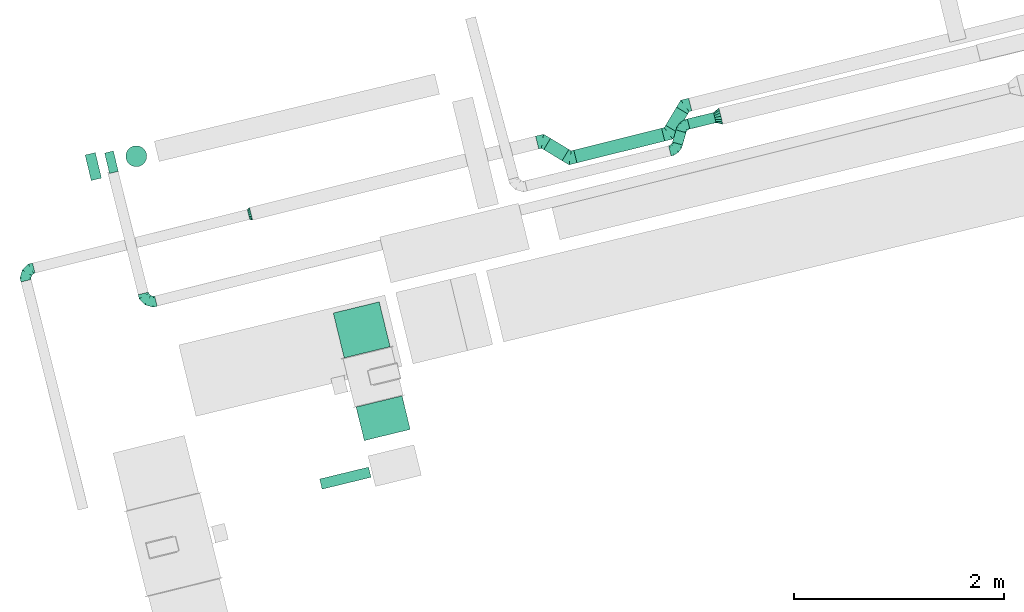
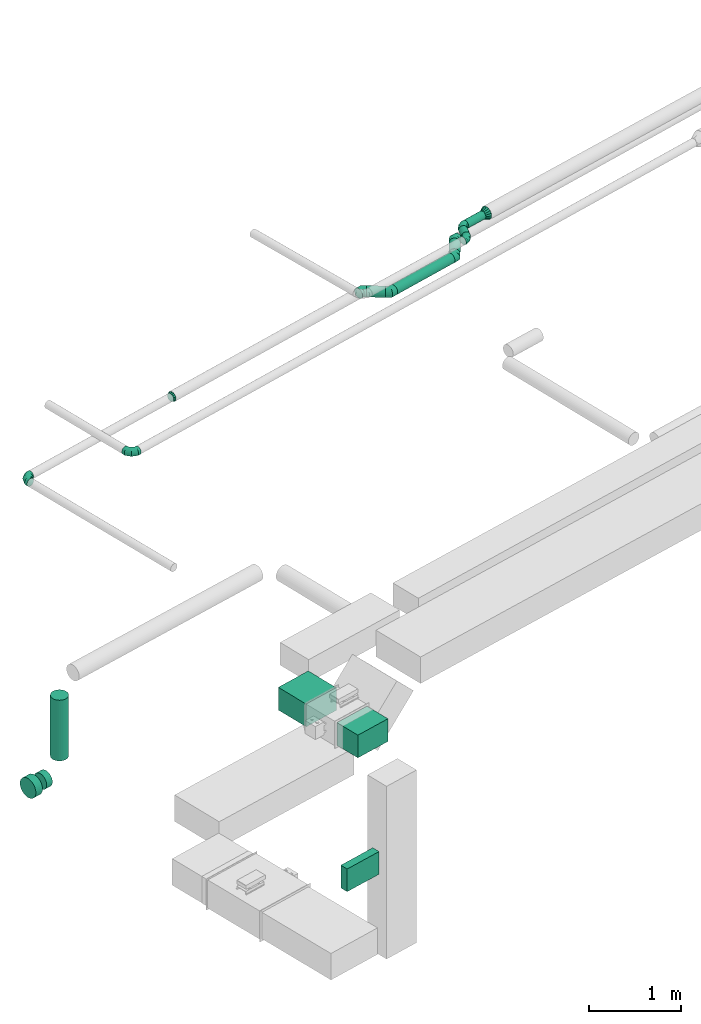
# One storey, part 86 of 337: 11 flow segments, 10 flow fittings.
"""IFC2X3 building model written with IfcOpenShell, lengths in millimetres."""

from ifc_helpers import new_model, entity, si_unit, converted_unit, derived_unit, direction, frame, origin, origin_2d_with_axis, place, context, subcontext, project, spatial, rectangle, circle, extrude, faceted_brep, source, transform, mapped, material, type_object, type_shapes, element, save


model = new_model("IFC2X3")

# Units and contexts
model_context = context("Model", 3, precision=0.01, world=origin(), true_north=direction((6.12303176911189e-17, 1.0)))
body_context = subcontext(model_context, "Body", "Model", "MODEL_VIEW")
ifc_project = project(units=[si_unit("LENGTHUNIT", "METRE", prefix="MILLI"), si_unit("AREAUNIT", "SQUARE_METRE"), si_unit("VOLUMEUNIT", "CUBIC_METRE"), converted_unit("PLANEANGLEUNIT", "DEGREE", entity("IfcRatioMeasure", 0.0174532925199433), si_unit("PLANEANGLEUNIT", "RADIAN"), dimensions=[0, 0, 0, 0, 0, 0, 0]), si_unit("MASSUNIT", "GRAM", prefix="KILO"), derived_unit("MASSDENSITYUNIT", [(si_unit("MASSUNIT", "GRAM", prefix="KILO"), 1), (si_unit("LENGTHUNIT", "METRE"), -3)]), derived_unit("MOMENTOFINERTIAUNIT", [(si_unit("LENGTHUNIT", "METRE"), 4)]), si_unit("TIMEUNIT", "SECOND"), si_unit("FREQUENCYUNIT", "HERTZ"), si_unit("THERMODYNAMICTEMPERATUREUNIT", "DEGREE_CELSIUS"), derived_unit("THERMALTRANSMITTANCEUNIT", [(si_unit("MASSUNIT", "GRAM", prefix="KILO"), 1), (si_unit("THERMODYNAMICTEMPERATUREUNIT", "KELVIN"), -1), (si_unit("TIMEUNIT", "SECOND"), -3)]), derived_unit("VOLUMETRICFLOWRATEUNIT", [(si_unit("LENGTHUNIT", "METRE"), 3), (si_unit("TIMEUNIT", "SECOND"), -1)]), derived_unit("MASSFLOWRATEUNIT", [(si_unit("MASSUNIT", "GRAM", prefix="KILO"), 1), (si_unit("TIMEUNIT", "SECOND"), -1)]), derived_unit("ROTATIONALFREQUENCYUNIT", [(si_unit("TIMEUNIT", "SECOND"), -1)]), si_unit("ELECTRICCURRENTUNIT", "AMPERE"), si_unit("ELECTRICVOLTAGEUNIT", "VOLT"), si_unit("POWERUNIT", "WATT"), si_unit("FORCEUNIT", "NEWTON", prefix="KILO"), si_unit("ILLUMINANCEUNIT", "LUX"), si_unit("LUMINOUSFLUXUNIT", "LUMEN"), si_unit("LUMINOUSINTENSITYUNIT", "CANDELA"), derived_unit("USERDEFINED", [(si_unit("MASSUNIT", "GRAM", prefix="KILO"), -1), (si_unit("LENGTHUNIT", "METRE"), -2), (si_unit("TIMEUNIT", "SECOND"), 3), (si_unit("LUMINOUSFLUXUNIT", "LUMEN"), 1)]), derived_unit("LINEARVELOCITYUNIT", [(si_unit("LENGTHUNIT", "METRE"), 1), (si_unit("TIMEUNIT", "SECOND"), -1)]), si_unit("PRESSUREUNIT", "PASCAL"), derived_unit("USERDEFINED", [(si_unit("LENGTHUNIT", "METRE"), -2), (si_unit("MASSUNIT", "GRAM", prefix="KILO"), 1), (si_unit("TIMEUNIT", "SECOND"), -2)]), derived_unit("LINEARFORCEUNIT", [(si_unit("MASSUNIT", "GRAM", prefix="KILO"), 1), (si_unit("LENGTHUNIT", "METRE"), 1), (si_unit("TIMEUNIT", "SECOND"), -2), (si_unit("LENGTHUNIT", "METRE"), -1)]), derived_unit("PLANARFORCEUNIT", [(si_unit("MASSUNIT", "GRAM", prefix="KILO"), 1), (si_unit("LENGTHUNIT", "METRE"), 1), (si_unit("TIMEUNIT", "SECOND"), -2), (si_unit("LENGTHUNIT", "METRE"), -2)])], contexts=[model_context])

# Site, building, storey
site_placement = place(None, origin())
site = spatial("IfcSite", under=ifc_project, at=site_placement, CompositionType="ELEMENT")
building_placement = place(site_placement, origin())
building = spatial("IfcBuilding", under=site, at=building_placement, CompositionType="ELEMENT")
storey_placement = place(building_placement, origin())
storey = spatial("IfcBuildingStorey", under=building, at=storey_placement, CompositionType="ELEMENT", Elevation=0.0)

# Flow segments
duct_segment_type_1 = type_object("IfcDuctSegmentType", PredefinedType="NOTDEFINED")
flow_segment_1_placement = place(storey_placement, frame((-22679.69, 8989.51, -750.05)))
element("IfcFlowSegment", 1, at=flow_segment_1_placement, inside=storey, type_object=duct_segment_type_1, context=body_context, shape_type="SweptSolid", body=[
    extrude(rectangle(XDim=329.333777520762, YDim=450.000000000001, at=origin_2d_with_axis()), frame((257.54, 213.19, 0.01), z_axis=(9.19986525435832e-06, -3.78240338182805e-05, 1.0), x_axis=(0.236337622980494, -0.97167099701938, -3.8926790966952e-05)), (0.0, 0.0, 1.0), 300.0),
])
flow_segment_2_placement = place(storey_placement, frame((-23027.47, 8526.62, -2100.0)))
element("IfcFlowSegment", 2, at=flow_segment_2_placement, inside=storey, type_object=duct_segment_type_1, context=body_context, shape_type="SweptSolid", body=[
    extrude(rectangle(XDim=479.999999999933, YDim=99.9999999999991, at=origin_2d_with_axis()), frame((245.02, 105.3, 0.0), z_axis=(0.0, 0.0, 1.0), x_axis=(-0.971670997755564, -0.236337623159555, 0.0)), (0.0, 0.0, 1.0), 300.0),
])
flow_segment_3_placement = place(storey_placement, frame((-22897.33, 9777.38, -750.02)))
element("IfcFlowSegment", 3, at=flow_segment_3_placement, inside=storey, type_object=duct_segment_type_1, context=body_context, shape_type="SweptSolid", body=[
    extrude(rectangle(XDim=439.417224696935, YDim=450.000000000001, at=origin_2d_with_axis()), frame((270.55, 266.66, 0.01), z_axis=(6.13714405959698e-06, -2.52342324608437e-05, 1.0), x_axis=(0.236318405347336, -0.971675671517848, -2.5969809877936e-05)), (0.0, 0.0, 1.0), 300.0),
])
duct_segment_type_2 = type_object("IfcDuctSegmentType", PredefinedType="NOTDEFINED")
flow_segment_4_placement = place(storey_placement, frame((-24875.0, 11596.21, -1603.0)))
element("IfcFlowSegment", 4, at=flow_segment_4_placement, inside=storey, type_object=duct_segment_type_2, context=body_context, shape_type="SweptSolid", body=[
    extrude(circle(Radius=100.0, at=origin_2d_with_axis()), frame((101.56, 101.56, 0.0), z_axis=(0.0, 0.0, 1.0), x_axis=(0.23334431467765, -0.972394174605966, 0.0)), (0.0, 0.0, 1.0), 802.999999147516),
])
flow_segment_5_placement = place(storey_placement, frame((-25262.35, 11464.69, -1929.6)))
element("IfcFlowSegment", 5, at=flow_segment_5_placement, inside=storey, type_object=duct_segment_type_2, context=body_context, shape_type="SweptSolid", body=[
    extrude(circle(Radius=125.0, at=origin_2d_with_axis()), frame((30.76, 123.14, 126.6), z_axis=(0.972394174605968, 0.23334431467764, 0.0), x_axis=(-0.23334431467764, 0.972394174605968, 0.0)), (0.0, 0.0, 1.0), 100.000000000002),
])
flow_segment_6_placement = place(storey_placement, frame((-25076.63, 11532.17, -1904.6)))
element("IfcFlowSegment", 6, at=flow_segment_6_placement, inside=storey, type_object=duct_segment_type_2, context=body_context, shape_type="SweptSolid", body=[
    extrude(circle(Radius=100.0, at=origin_2d_with_axis()), frame((24.93, 98.83, 101.6), z_axis=(0.972394174605965, 0.233344314677655, 0.0), x_axis=(-0.233344314677655, 0.972394174605965, 0.0)), (0.0, 0.0, 1.0), 86.1557080929666),
])
flow_segment_7_placement = place(storey_placement, frame((-20894.58, 11653.85, 3035.9)))
element("IfcFlowSegment", 7, at=flow_segment_7_placement, inside=storey, type_object=duct_segment_type_2, context=body_context, shape_type="SweptSolid", body=[
    extrude(circle(Radius=62.5, at=origin_2d_with_axis()), frame((33.79, 160.28, 64.1), z_axis=(0.857167300702083, -0.515038074910103, 0.0), x_axis=(-0.515038074910103, -0.857167300702083, 0.0)), (0.0, 0.0, 1.0), 204.087208353514),
])
flow_segment_8_placement = place(storey_placement, frame((-20607.95, 11632.64, 3035.9)))
element("IfcFlowSegment", 8, at=flow_segment_8_placement, inside=storey, type_object=duct_segment_type_2, context=body_context, shape_type="SweptSolid", body=[
    extrude(circle(Radius=62.5, at=origin_2d_with_axis()), frame((16.72, 62.24, 64.1), z_axis=(0.970295726275994, 0.241921895599677, 0.0), x_axis=(0.241921895599677, -0.970295726275994, 0.0)), (0.0, 0.0, 1.0), 861.446609406775),
])
flow_segment_9_placement = place(storey_placement, frame((-19733.64, 11926.4, 3035.9)))
element("IfcFlowSegment", 9, at=flow_segment_9_placement, inside=storey, type_object=duct_segment_type_2, context=body_context, shape_type="SweptSolid", body=[
    extrude(circle(Radius=62.5, at=origin_2d_with_axis()), frame((55.17, 33.79, 64.1), z_axis=(0.515038074910051, 0.857167300702114, 0.0), x_axis=(0.857167300702114, -0.515038074910051, 0.0)), (0.0, 0.0, 1.0), 201.446609406677),
])
flow_segment_10_placement = place(storey_placement, frame((-19526.76, 11954.73, 3348.4)))
element("IfcFlowSegment", 10, at=flow_segment_10_placement, inside=storey, type_object=duct_segment_type_2, context=body_context, shape_type="SweptSolid", body=[
    extrude(circle(Radius=50.0, at=origin_2d_with_axis()), frame((13.44, 50.17, 51.6), z_axis=(0.971552058141482, 0.2368260929903, 0.0), x_axis=(-0.2368260929903, 0.971552058141482, 0.0)), (0.0, 0.0, 1.0), 256.179803746256),
])
flow_segment_11_placement = place(storey_placement, frame((-19668.91, 11803.18, 3348.4)))
element("IfcFlowSegment", 11, at=flow_segment_11_placement, inside=storey, type_object=duct_segment_type_2, context=body_context, shape_type="SweptSolid", body=[
    extrude(circle(Radius=50.0, at=origin_2d_with_axis()), frame((49.66, 15.38, 51.6), z_axis=(0.275637355817032, 0.961261695938309, 0.0), x_axis=(-0.961261695938309, 0.275637355817032, 0.0)), (0.0, 0.0, 1.0), 121.459538155971),
])

# Flow fittings
ifc_material = material()
duct_fitting_type_1 = type_object("IfcDuctFittingType", PredefinedType="NOTDEFINED", material=ifc_material)
shared_shape_1 = source(origin(), body_context, "Body", "Brep", [
    faceted_brep([(-100.0, 0.0, -50.0), (-100.0, -12.94, -48.3), (-100.0, -25.0, -43.3), (-100.0, -35.36, -35.36), (-100.0, -43.3, -25.0), (-100.0, -48.3, -12.94), (-100.0, -50.0, 0.0), (-100.0, -48.3, 12.94), (-100.0, -43.3, 25.0), (-100.0, -35.36, 35.36), (-100.0, -25.0, 43.3), (-100.0, -12.94, 48.3), (-100.0, 0.0, 50.0), (-100.0, 12.94, 48.3), (-100.0, 25.0, 43.3), (-100.0, 35.36, 35.36), (-100.0, 43.3, 25.0), (-100.0, 48.3, 12.94), (-100.0, 50.0, 0.0), (-100.0, 48.3, -12.94), (-100.0, 43.3, -25.0), (-100.0, 35.36, -35.36), (-100.0, 25.0, -43.3), (-100.0, 12.94, -48.3), (-76.67, 12.94, 48.3), (-79.9, 25.0, 43.3), (-73.21, 0.0, 50.0), (-82.68, 35.36, 35.36), (-86.15, 48.3, 12.94), (-86.6, 50.0, 0.0), (-84.81, 43.3, 25.0), (-84.81, 43.3, -25.0), (-82.68, 35.36, -35.36), (-86.15, 48.3, -12.94), (-76.67, 12.94, -48.3), (-73.21, 0.0, -50.0), (-79.9, 25.0, -43.3), (-69.74, -12.94, -48.3), (-66.51, -25.0, -43.3), (-63.73, -35.36, -35.36), (-61.6, -43.3, -25.0), (-60.26, -48.3, -12.94), (-59.81, -50.0, 0.0), (-60.26, -48.3, 12.94), (-61.6, -43.3, 25.0), (-63.73, -35.36, 35.36), (-66.51, -25.0, 43.3), (-69.74, -12.94, 48.3), (-36.27, 36.27, 48.3), (-45.1, 45.1, 43.3), (-26.79, 26.79, 50.0), (-52.68, 52.68, 35.36), (-58.49, 58.49, 25.0), (-62.15, 62.15, 12.94), (-63.4, 63.4, 0.0), (-62.15, 62.15, -12.94), (-58.49, 58.49, -25.0), (-52.68, 52.68, -35.36), (-36.27, 36.27, -48.3), (-26.79, 26.79, -50.0), (-45.1, 45.1, -43.3), (-17.32, 17.32, -48.3), (-8.49, 8.49, -43.3), (-0.91, 0.91, -35.36), (4.9, -4.9, -25.0), (8.56, -8.56, -12.94), (9.81, -9.81, 0.0), (8.56, -8.56, 12.94), (4.9, -4.9, 25.0), (-0.91, 0.91, 35.36), (-8.49, 8.49, 43.3), (-17.32, 17.32, 48.3), (-12.94, 76.67, 48.3), (-25.0, 79.9, 43.3), (0.0, 73.21, 50.0), (-35.36, 82.68, 35.36), (-43.3, 84.81, 25.0), (-48.3, 86.15, 12.94), (-50.0, 86.6, 0.0), (-48.3, 86.15, -12.94), (-43.3, 84.81, -25.0), (-35.36, 82.68, -35.36), (-12.94, 76.67, -48.3), (0.0, 73.21, -50.0), (-25.0, 79.9, -43.3), (12.94, 69.74, -48.3), (25.0, 66.51, -43.3), (35.36, 63.73, -35.36), (43.3, 61.6, -25.0), (48.3, 60.26, -12.94), (50.0, 59.81, 0.0), (48.3, 60.26, 12.94), (43.3, 61.6, 25.0), (35.36, 63.73, 35.36), (25.0, 66.51, 43.3), (12.94, 69.74, 48.3), (-12.94, 100.0, -48.3), (-25.0, 100.0, -43.3), (-35.36, 100.0, -35.36), (-43.3, 100.0, -25.0), (-48.3, 100.0, -12.94), (-50.0, 100.0, 0.0), (-48.3, 100.0, 12.94), (-43.3, 100.0, 25.0), (-35.36, 100.0, 35.36), (-25.0, 100.0, 43.3), (-12.94, 100.0, 48.3), (0.0, 100.0, 50.0), (12.94, 100.0, 48.3), (25.0, 100.0, 43.3), (35.36, 100.0, 35.36), (43.3, 100.0, 25.0), (48.3, 100.0, 12.94), (50.0, 100.0, 0.0), (48.3, 100.0, -12.94), (43.3, 100.0, -25.0), (35.36, 100.0, -35.36), (25.0, 100.0, -43.3), (12.94, 100.0, -48.3), (0.0, 100.0, -50.0)], [[[0, 1, 2, 3, 4, 5, 6, 7, 8, 9, 10, 11, 12, 13, 14, 15, 16, 17, 18, 19, 20, 21, 22, 23]], [[24, 25, 14, 13]], [[26, 24, 13, 12]], [[14, 25, 27, 15]], [[28, 29, 18, 17]], [[30, 28, 17, 16]], [[15, 27, 30, 16]], [[20, 31, 32, 21]], [[33, 31, 20, 19]], [[18, 29, 33, 19]], [[34, 35, 0, 23]], [[36, 34, 23, 22]], [[32, 36, 22, 21]], [[2, 1, 37, 38]], [[3, 2, 38, 39]], [[0, 35, 37, 1]], [[5, 4, 40, 41]], [[6, 5, 41, 42]], [[3, 39, 40, 4]], [[6, 42, 43, 7]], [[7, 43, 44, 8]], [[8, 44, 45, 9]], [[10, 46, 47, 11]], [[11, 47, 26, 12]], [[10, 9, 45, 46]], [[48, 49, 25, 24]], [[50, 48, 24, 26]], [[27, 25, 49, 51]], [[52, 53, 28, 30]], [[51, 52, 30, 27]], [[29, 28, 53, 54]], [[55, 56, 31, 33]], [[54, 55, 33, 29]], [[57, 32, 31, 56]], [[58, 59, 35, 34]], [[60, 58, 34, 36]], [[57, 60, 36, 32]], [[37, 35, 59, 61]], [[38, 37, 61, 62]], [[39, 38, 62, 63]], [[41, 40, 64, 65]], [[42, 41, 65, 66]], [[63, 64, 40, 39]], [[43, 42, 66, 67]], [[44, 43, 67, 68]], [[68, 69, 45, 44]], [[46, 45, 69, 70]], [[47, 46, 70, 71]], [[26, 47, 71, 50]], [[72, 73, 49, 48]], [[74, 72, 48, 50]], [[51, 49, 73, 75]], [[76, 77, 53, 52]], [[75, 76, 52, 51]], [[54, 53, 77, 78]], [[79, 80, 56, 55]], [[78, 79, 55, 54]], [[81, 57, 56, 80]], [[82, 83, 59, 58]], [[84, 82, 58, 60]], [[81, 84, 60, 57]], [[61, 59, 83, 85]], [[62, 61, 85, 86]], [[63, 62, 86, 87]], [[65, 64, 88, 89]], [[66, 65, 89, 90]], [[87, 88, 64, 63]], [[67, 66, 90, 91]], [[68, 67, 91, 92]], [[92, 93, 69, 68]], [[70, 69, 93, 94]], [[71, 70, 94, 95]], [[50, 71, 95, 74]], [[96, 97, 98, 99, 100, 101, 102, 103, 104, 105, 106, 107, 108, 109, 110, 111, 112, 113, 114, 115, 116, 117, 118, 119]], [[72, 74, 107, 106]], [[73, 72, 106, 105]], [[75, 73, 105, 104]], [[77, 76, 103, 102]], [[78, 77, 102, 101]], [[75, 104, 103, 76]], [[78, 101, 100, 79]], [[79, 100, 99, 80]], [[80, 99, 98, 81]], [[96, 119, 83, 82]], [[97, 96, 82, 84]], [[84, 81, 98, 97]], [[83, 119, 118, 85]], [[85, 118, 117, 86]], [[86, 117, 116, 87]], [[88, 115, 114, 89]], [[89, 114, 113, 90]], [[87, 116, 115, 88]], [[91, 90, 113, 112]], [[92, 91, 112, 111]], [[93, 92, 111, 110]], [[95, 94, 109, 108]], [[74, 95, 108, 107]], [[110, 109, 94, 93]]]),
])
type_shapes(duct_fitting_type_1, [shared_shape_1])
for number, where, z_axis, x_axis in (
    (12, (-24683.17, 10294.31, 3210.0), (0.0, 0.0, 1.0), (0.24192189559965, -0.970295726276001, 0.0)),
    (13, (-25846.8, 10608.72, 3100.0), (0.0, 0.0, 1.0), (-0.970295726275997, -0.241921895599666, 0.0)),
):
    element("IfcFlowFitting", number, at=place(storey_placement, frame(where, z_axis=z_axis, x_axis=x_axis)), inside=storey, type_object=duct_fitting_type_1, material=ifc_material, context=body_context, shape_type="MappedRepresentation", body=[
        mapped(shared_shape_1, transform((0.0, 0.0, 0.0), scale=1.0)),
    ])
duct_fitting_type_2 = type_object("IfcDuctFittingType", PredefinedType="NOTDEFINED", material=ifc_material)
shared_shape_2 = source(origin(), body_context, "Body", "Brep", [
    faceted_brep([(-51.78, 0.0, -62.5), (-51.78, -16.18, -60.37), (-51.78, -31.25, -54.13), (-51.78, -44.19, -44.19), (-51.78, -54.13, -31.25), (-51.78, -60.37, -16.18), (-51.78, -62.5, 0.0), (-51.78, -60.37, 16.18), (-51.78, -54.13, 31.25), (-51.78, -44.19, 44.19), (-51.78, -31.25, 54.13), (-51.78, -16.18, 60.37), (-51.78, 0.0, 62.5), (-51.78, 16.18, 60.37), (-51.78, 31.25, 54.13), (-51.78, 44.19, 44.19), (-51.78, 54.13, 31.25), (-51.78, 60.37, 16.18), (-51.78, 62.5, 0.0), (-51.78, 60.37, -16.18), (-51.78, 54.13, -31.25), (-51.78, 44.19, -44.19), (-51.78, 31.25, -54.13), (-51.78, 16.18, -60.37), (-6.7, 16.18, 60.37), (-12.94, 31.25, 54.13), (0.0, 0.0, 62.5), (-18.31, 44.19, 44.19), (-22.42, 54.13, 31.25), (-25.01, 60.37, 16.18), (-25.89, 62.5, 0.0), (-25.01, 60.37, -16.18), (-22.42, 54.13, -31.25), (-18.31, 44.19, -44.19), (-6.7, 16.18, -60.37), (0.0, 0.0, -62.5), (-12.94, 31.25, -54.13), (6.7, -16.18, -60.37), (12.94, -31.25, -54.13), (18.31, -44.19, -44.19), (22.42, -54.13, -31.25), (25.01, -60.37, -16.18), (25.89, -62.5, 0.0), (25.01, -60.37, 16.18), (22.42, -54.13, 31.25), (18.31, -44.19, 44.19), (12.94, -31.25, 54.13), (6.7, -16.18, 60.37), (25.17, 48.05, 60.37), (14.51, 58.71, 54.13), (36.61, 36.61, 62.5), (5.36, 67.86, 44.19), (-1.66, 74.88, 31.25), (-6.08, 79.3, 16.18), (-7.58, 80.81, 0.0), (-6.08, 79.3, -16.18), (-1.66, 74.88, -31.25), (5.36, 67.86, -44.19), (14.51, 58.71, -54.13), (25.17, 48.05, -60.37), (36.61, 36.61, -62.5), (48.05, 25.17, -60.37), (58.71, 14.51, -54.13), (67.86, 5.36, -44.19), (74.88, -1.66, -31.25), (79.3, -6.08, -16.18), (80.81, -7.58, 0.0), (79.3, -6.08, 16.18), (74.88, -1.66, 31.25), (67.86, 5.36, 44.19), (58.71, 14.51, 54.13), (48.05, 25.17, 60.37)], [[[0, 1, 2, 3, 4, 5, 6, 7, 8, 9, 10, 11, 12, 13, 14, 15, 16, 17, 18, 19, 20, 21, 22, 23]], [[24, 25, 14, 13]], [[26, 24, 13, 12]], [[27, 15, 14, 25]], [[28, 29, 17, 16]], [[28, 16, 15, 27]], [[30, 18, 17, 29]], [[31, 32, 20, 19]], [[30, 31, 19, 18]], [[21, 20, 32, 33]], [[34, 35, 0, 23]], [[36, 34, 23, 22]], [[33, 36, 22, 21]], [[1, 0, 35, 37]], [[2, 1, 37, 38]], [[38, 39, 3, 2]], [[5, 4, 40, 41]], [[6, 5, 41, 42]], [[39, 40, 4, 3]], [[6, 42, 43, 7]], [[7, 43, 44, 8]], [[8, 44, 45, 9]], [[9, 45, 46, 10]], [[10, 46, 47, 11]], [[26, 12, 11, 47]], [[48, 49, 25, 24]], [[50, 48, 24, 26]], [[27, 25, 49, 51]], [[29, 28, 52, 53]], [[30, 29, 53, 54]], [[51, 52, 28, 27]], [[30, 54, 55, 31]], [[31, 55, 56, 32]], [[57, 33, 32, 56]], [[36, 58, 59, 34]], [[34, 59, 60, 35]], [[58, 36, 33, 57]], [[35, 60, 61, 37]], [[37, 61, 62, 38]], [[63, 39, 38, 62]], [[40, 64, 65, 41]], [[41, 65, 66, 42]], [[64, 40, 39, 63]], [[43, 42, 66, 67]], [[44, 43, 67, 68]], [[68, 69, 45, 44]], [[47, 46, 70, 71]], [[26, 47, 71, 50]], [[69, 70, 46, 45]], [[59, 58, 57, 56, 55, 54, 53, 52, 51, 49, 48, 50, 71, 70, 69, 68, 67, 66, 65, 64, 63, 62, 61, 60]]]),
])
type_shapes(duct_fitting_type_2, [shared_shape_2])
for number, where, z_axis, x_axis in (
    (14, (-20905.18, 11840.8, 3100.0), (0.0, 0.0, 1.0), (-0.85716730070211, 0.515038074910058, 0.0)),
    (15, (-20641.48, 11682.35, 3100.0), (0.0, 0.0, 1.0), (0.857167300702084, -0.515038074910101, 0.0)),
    (16, (-19705.14, 11915.81, 3100.0), (0.0, 0.0, 1.0), (0.970295726275993, 0.241921895599682, 0.0)),
    (17, (-19548.06, 12177.24, 3100.0), (0.0, 0.0, 1.0), (-0.970295726275996, -0.241921895599668, 0.0)),
):
    element("IfcFlowFitting", number, at=place(storey_placement, frame(where, z_axis=z_axis, x_axis=x_axis)), inside=storey, type_object=duct_fitting_type_2, material=ifc_material, context=body_context, shape_type="MappedRepresentation", body=[
        mapped(shared_shape_2, transform((0.0, 0.0, 0.0), scale=1.0)),
    ])
duct_fitting_type_3 = type_object("IfcDuctFittingType", PredefinedType="NOTDEFINED", material=ifc_material)
shared_shape_3 = source(origin(), body_context, "Body", "Brep", [
    faceted_brep([(60.0, -46.19, 19.13), (60.0, -48.1, 9.57), (60.0, -50.0, 0.0), (60.0, -48.1, -9.57), (60.0, -46.19, -19.13), (60.0, -40.77, -27.24), (60.0, -35.36, -35.36), (60.0, -27.24, -40.77), (60.0, -19.13, -46.19), (60.0, -9.57, -48.1), (60.0, 0.0, -50.0), (60.0, 9.57, -48.1), (60.0, 19.13, -46.19), (60.0, 27.24, -40.77), (60.0, 35.36, -35.36), (60.0, 40.77, -27.24), (60.0, 46.19, -19.13), (60.0, 48.1, -9.57), (60.0, 50.0, 0.0), (60.0, 48.1, 9.57), (60.0, 46.19, 19.13), (60.0, 40.77, 27.24), (60.0, 35.36, 35.36), (60.0, 27.24, 40.77), (60.0, 19.13, 46.19), (60.0, 9.57, 48.1), (60.0, 0.0, 50.0), (60.0, -9.57, 48.1), (60.0, -19.13, 46.19), (60.0, -27.24, 40.77), (60.0, -35.36, 35.36), (60.0, -40.77, 27.24), (0.0, -80.0, 0.0), (0.0, -77.16, 14.27), (0.0, -73.91, 30.61), (0.0, -65.24, 43.59), (0.0, -56.57, 56.57), (0.0, -43.59, 65.24), (0.0, -30.61, 73.91), (0.0, -15.31, 76.96), (0.0, 0.0, 80.0), (0.0, 14.27, 77.16), (0.0, 30.61, 73.91), (0.0, 43.59, 65.24), (0.0, 56.57, 56.57), (0.0, 65.24, 43.59), (0.0, 73.91, 30.61), (0.0, 76.96, 15.31), (0.0, 80.0, 0.0), (0.0, 77.16, -14.27), (0.0, 73.91, -30.61), (0.0, 65.24, -43.59), (0.0, 56.57, -56.57), (0.0, 43.59, -65.24), (0.0, 30.61, -73.91), (0.0, 15.31, -76.96), (0.0, 0.0, -80.0), (0.0, -14.27, -77.16), (0.0, -30.61, -73.91), (0.0, -43.59, -65.24), (0.0, -56.57, -56.57), (0.0, -65.24, -43.59), (0.0, -73.91, -30.61), (0.0, -76.96, -15.31)], [[[0, 1, 2, 3, 4, 5, 6, 7, 8, 9, 10, 11, 12, 13, 14, 15, 16, 17, 18, 19, 20, 21, 22, 23, 24, 25, 26, 27, 28, 29, 30, 31]], [[32, 33, 34, 35, 36, 37, 38, 39, 40, 41, 42, 43, 44, 45, 46, 47, 48, 49, 50, 51, 52, 53, 54, 55, 56, 57, 58, 59, 60, 61, 62, 63]], [[42, 41, 40, 26, 25, 24]], [[43, 42, 24, 23, 22, 44]], [[20, 46, 45, 44, 22, 21]], [[18, 48, 47, 46, 20, 19]], [[34, 33, 32, 2, 1, 0]], [[35, 34, 0, 31, 30, 36]], [[28, 38, 37, 36, 30, 29]], [[26, 40, 39, 38, 28, 27]], [[58, 57, 56, 10, 9, 8]], [[59, 58, 8, 7, 6, 60]], [[4, 62, 61, 60, 6, 5]], [[2, 32, 63, 62, 4, 3]], [[50, 49, 48, 18, 17, 16]], [[51, 50, 16, 15, 14, 52]], [[12, 54, 53, 52, 14, 13]], [[10, 56, 55, 54, 12, 11]]]),
])
type_shapes(duct_fitting_type_3, [shared_shape_3])
flow_fitting_1_placement = place(storey_placement, frame((-19206.14, 12079.79, 3400.0), z_axis=(0.0, 0.0, 1.0), x_axis=(-0.971552058141472, -0.236826092990341, 0.0)))
element("IfcFlowFitting", 18, at=flow_fitting_1_placement, inside=storey, type_object=duct_fitting_type_3, material=ifc_material, context=body_context, shape_type="MappedRepresentation", body=[
    mapped(shared_shape_3, transform((0.0, 0.0, 0.0), scale=1.0)),
])
duct_fitting_type_4 = type_object("IfcDuctFittingType", PredefinedType="NOTDEFINED", material=ifc_material)
shared_shape_4 = source(origin(), body_context, "Body", "Brep", [
    faceted_brep([(25.0, 0.0, -62.5), (25.0, 12.45, -60.02), (25.0, 23.92, -57.74), (25.0, 34.06, -50.97), (25.0, 44.19, -44.19), (25.0, 50.97, -34.06), (25.0, 57.74, -23.92), (25.0, 60.02, -12.45), (25.0, 62.5, 0.0), (25.0, 60.02, 12.45), (25.0, 57.74, 23.92), (25.0, 50.97, 34.06), (25.0, 44.19, 44.19), (25.0, 34.06, 50.97), (25.0, 23.92, 57.74), (25.0, 12.45, 60.02), (25.0, 0.0, 62.5), (25.0, -12.45, 60.02), (25.0, -23.92, 57.74), (25.0, -34.06, 50.97), (25.0, -44.19, 44.19), (25.0, -50.97, 34.06), (25.0, -57.74, 23.92), (25.0, -60.02, 12.45), (25.0, -62.5, 0.0), (25.0, -60.02, -12.45), (25.0, -57.74, -23.92), (25.0, -50.97, -34.06), (25.0, -44.19, -44.19), (25.0, -34.06, -50.97), (25.0, -23.92, -57.74), (25.0, -12.45, -60.02), (0.0, -19.13, -46.19), (0.0, -27.24, -40.77), (0.0, -35.36, -35.36), (0.0, -40.77, -27.24), (0.0, -46.19, -19.13), (0.0, -48.1, -9.57), (0.0, -50.0, 0.0), (0.0, -48.1, 9.57), (0.0, -46.19, 19.13), (0.0, -40.77, 27.24), (0.0, -35.36, 35.36), (0.0, -27.24, 40.77), (0.0, -19.13, 46.19), (0.0, -9.57, 48.1), (0.0, 0.0, 50.0), (0.0, 9.57, 48.1), (0.0, 19.13, 46.19), (0.0, 27.24, 40.77), (0.0, 35.36, 35.36), (0.0, 40.77, 27.24), (0.0, 46.19, 19.13), (0.0, 48.1, 9.57), (0.0, 50.0, 0.0), (0.0, 48.1, -9.57), (0.0, 46.19, -19.13), (0.0, 40.77, -27.24), (0.0, 35.36, -35.36), (0.0, 27.24, -40.77), (0.0, 19.13, -46.19), (0.0, 9.57, -48.1), (0.0, 0.0, -50.0), (0.0, -9.57, -48.1)], [[[0, 1, 2, 3, 4, 5, 6, 7, 8, 9, 10, 11, 12, 13, 14, 15, 16, 17, 18, 19, 20, 21, 22, 23, 24, 25, 26, 27, 28, 29, 30, 31]], [[32, 33, 34, 35, 36, 37, 38, 39, 40, 41, 42, 43, 44, 45, 46, 47, 48, 49, 50, 51, 52, 53, 54, 55, 56, 57, 58, 59, 60, 61, 62, 63]], [[52, 10, 9, 8, 54, 53]], [[51, 50, 12, 11, 10, 52]], [[47, 46, 16, 15, 14, 48]], [[49, 48, 14, 13, 12, 50]], [[44, 18, 17, 16, 46, 45]], [[43, 42, 20, 19, 18, 44]], [[39, 38, 24, 23, 22, 40]], [[41, 40, 22, 21, 20, 42]], [[36, 26, 25, 24, 38, 37]], [[35, 34, 28, 27, 26, 36]], [[63, 62, 0, 31, 30, 32]], [[33, 32, 30, 29, 28, 34]], [[60, 2, 1, 0, 62, 61]], [[59, 58, 4, 3, 2, 60]], [[55, 54, 8, 7, 6, 56]], [[57, 56, 6, 5, 4, 58]]]),
])
type_shapes(duct_fitting_type_4, [shared_shape_4])
flow_fitting_2_placement = place(storey_placement, frame((-23704.48, 11142.86, 3100.0), z_axis=(0.0, 0.0, 1.0), x_axis=(0.970295726275998, 0.241921895599663, 0.0)))
element("IfcFlowFitting", 19, at=flow_fitting_2_placement, inside=storey, type_object=duct_fitting_type_4, material=ifc_material, context=body_context, shape_type="MappedRepresentation", body=[
    mapped(shared_shape_4, transform((0.0, 0.0, 0.0), scale=1.0)),
])
duct_fitting_type_5 = type_object("IfcDuctFittingType", PredefinedType="NOTDEFINED", material=ifc_material)
shared_shape_5 = source(origin(), body_context, "Body", "Brep", [
    faceted_brep([(-58.09, 0.0, -50.0), (-58.09, -12.94, -48.3), (-58.09, -25.0, -43.3), (-58.09, -35.36, -35.36), (-58.09, -43.3, -25.0), (-58.09, -48.3, -12.94), (-58.09, -50.0, 0.0), (-58.09, -48.3, 12.94), (-58.09, -43.3, 25.0), (-58.09, -35.36, 35.36), (-58.09, -25.0, 43.3), (-58.09, -12.94, 48.3), (-58.09, 0.0, 50.0), (-58.09, 12.94, 48.3), (-58.09, 25.0, 43.3), (-58.09, 35.36, 35.36), (-58.09, 43.3, 25.0), (-58.09, 48.3, 12.94), (-58.09, 50.0, 0.0), (-58.09, 48.3, -12.94), (-58.09, 43.3, -25.0), (-58.09, 35.36, -35.36), (-58.09, 25.0, -43.3), (-58.09, 12.94, -48.3), (-42.66, 12.94, 48.3), (-44.79, 25.0, 43.3), (-40.36, 0.0, 50.0), (-46.63, 35.36, 35.36), (-48.92, 48.3, 12.94), (-49.22, 50.0, 0.0), (-48.04, 43.3, 25.0), (-48.04, 43.3, -25.0), (-46.63, 35.36, -35.36), (-48.92, 48.3, -12.94), (-42.66, 12.94, -48.3), (-40.36, 0.0, -50.0), (-44.79, 25.0, -43.3), (-38.07, -12.94, -48.3), (-35.93, -25.0, -43.3), (-34.1, -35.36, -35.36), (-32.69, -43.3, -25.0), (-31.8, -48.3, -12.94), (-31.5, -50.0, 0.0), (-31.8, -48.3, 12.94), (-32.69, -43.3, 25.0), (-34.1, -35.36, 35.36), (-35.93, -25.0, 43.3), (-38.07, -12.94, 48.3), (-13.68, 23.55, 48.3), (-19.83, 34.14, 43.3), (-7.08, 12.18, 50.0), (-25.11, 43.23, 35.36), (-31.71, 54.59, 12.94), (-32.58, 56.09, 0.0), (-29.16, 50.21, 25.0), (-29.16, 50.21, -25.0), (-25.11, 43.23, -35.36), (-31.71, 54.59, -12.94), (-13.68, 23.55, -48.3), (-7.08, 12.18, -50.0), (-19.83, 34.14, -43.3), (-0.47, 0.82, -48.3), (5.68, -9.77, -43.3), (10.96, -18.87, -35.36), (15.01, -25.85, -25.0), (17.56, -30.23, -12.94), (18.43, -31.73, 0.0), (17.56, -30.23, 12.94), (15.01, -25.85, 25.0), (10.96, -18.87, 35.36), (5.68, -9.77, 43.3), (-0.47, 0.82, 48.3), (9.89, 43.46, 48.3), (0.48, 51.3, 43.3), (20.0, 35.06, 50.0), (-7.61, 58.02, 35.36), (-17.71, 66.42, 12.94), (-19.04, 67.53, 0.0), (-13.81, 63.18, 25.0), (-13.81, 63.18, -25.0), (-7.61, 58.02, -35.36), (-17.71, 66.42, -12.94), (9.89, 43.46, -48.3), (20.0, 35.06, -50.0), (0.48, 51.3, -43.3), (30.1, 26.66, -48.3), (39.52, 18.83, -43.3), (47.6, 12.1, -35.36), (53.81, 6.94, -25.0), (57.71, 3.7, -12.94), (59.04, 2.59, 0.0), (57.71, 3.7, 12.94), (53.81, 6.94, 25.0), (47.6, 12.1, 35.36), (39.52, 18.83, 43.3), (30.1, 26.66, 48.3), (17.54, 56.87, -48.3), (7.06, 62.84, -43.3), (-1.93, 67.97, -35.36), (-8.83, 71.91, -25.0), (-13.17, 74.38, -12.94), (-14.65, 75.23, 0.0), (-13.17, 74.38, 12.94), (-8.83, 71.91, 25.0), (-1.93, 67.97, 35.36), (7.06, 62.84, 43.3), (17.54, 56.87, 48.3), (28.78, 50.46, 50.0), (40.02, 44.04, 48.3), (50.49, 38.07, 43.3), (59.49, 32.94, 35.36), (66.39, 29.0, 25.0), (70.73, 26.53, 12.94), (72.21, 25.68, 0.0), (70.73, 26.53, -12.94), (66.39, 29.0, -25.0), (59.49, 32.94, -35.36), (50.49, 38.07, -43.3), (40.02, 44.04, -48.3), (28.78, 50.46, -50.0)], [[[0, 1, 2, 3, 4, 5, 6, 7, 8, 9, 10, 11, 12, 13, 14, 15, 16, 17, 18, 19, 20, 21, 22, 23]], [[24, 25, 14, 13]], [[26, 24, 13, 12]], [[14, 25, 27, 15]], [[28, 29, 18, 17]], [[30, 28, 17, 16]], [[15, 27, 30, 16]], [[20, 31, 32, 21]], [[33, 31, 20, 19]], [[18, 29, 33, 19]], [[34, 35, 0, 23]], [[36, 34, 23, 22]], [[32, 36, 22, 21]], [[2, 1, 37, 38]], [[3, 2, 38, 39]], [[0, 35, 37, 1]], [[5, 4, 40, 41]], [[6, 5, 41, 42]], [[39, 40, 4, 3]], [[6, 42, 43, 7]], [[7, 43, 44, 8]], [[8, 44, 45, 9]], [[10, 46, 47, 11]], [[11, 47, 26, 12]], [[9, 45, 46, 10]], [[48, 49, 25, 24]], [[50, 48, 24, 26]], [[25, 49, 51, 27]], [[52, 53, 29, 28]], [[54, 52, 28, 30]], [[30, 27, 51, 54]], [[55, 56, 32, 31]], [[57, 55, 31, 33]], [[53, 57, 33, 29]], [[58, 59, 35, 34]], [[60, 58, 34, 36]], [[32, 56, 60, 36]], [[35, 59, 61, 37]], [[37, 61, 62, 38]], [[39, 38, 62, 63]], [[41, 40, 64, 65]], [[42, 41, 65, 66]], [[63, 64, 40, 39]], [[42, 66, 67, 43]], [[44, 43, 67, 68]], [[68, 69, 45, 44]], [[46, 45, 69, 70]], [[47, 46, 70, 71]], [[26, 47, 71, 50]], [[72, 73, 49, 48]], [[74, 72, 48, 50]], [[49, 73, 75, 51]], [[76, 77, 53, 52]], [[78, 76, 52, 54]], [[54, 51, 75, 78]], [[79, 80, 56, 55]], [[81, 79, 55, 57]], [[77, 81, 57, 53]], [[82, 83, 59, 58]], [[84, 82, 58, 60]], [[56, 80, 84, 60]], [[59, 83, 85, 61]], [[61, 85, 86, 62]], [[63, 62, 86, 87]], [[65, 64, 88, 89]], [[66, 65, 89, 90]], [[87, 88, 64, 63]], [[66, 90, 91, 67]], [[68, 67, 91, 92]], [[92, 93, 69, 68]], [[70, 69, 93, 94]], [[71, 70, 94, 95]], [[50, 71, 95, 74]], [[96, 97, 98, 99, 100, 101, 102, 103, 104, 105, 106, 107, 108, 109, 110, 111, 112, 113, 114, 115, 116, 117, 118, 119]], [[72, 74, 107, 106]], [[73, 72, 106, 105]], [[75, 73, 105, 104]], [[76, 78, 103, 102]], [[77, 76, 102, 101]], [[75, 104, 103, 78]], [[77, 101, 100, 81]], [[81, 100, 99, 79]], [[79, 99, 98, 80]], [[84, 97, 96, 82]], [[82, 96, 119, 83]], [[84, 80, 98, 97]], [[83, 119, 118, 85]], [[85, 118, 117, 86]], [[86, 117, 116, 87]], [[88, 115, 114, 89]], [[89, 114, 113, 90]], [[87, 116, 115, 88]], [[91, 90, 113, 112]], [[92, 91, 112, 111]], [[93, 92, 111, 110]], [[95, 94, 109, 108]], [[74, 95, 108, 107]], [[110, 109, 94, 93]]]),
])
type_shapes(duct_fitting_type_5, [shared_shape_5])
for number, where, z_axis, x_axis in (
    (20, (-19569.76, 11991.15, 3400.0), (0.0, 0.0, 1.0), (-0.97155205814147, -0.236826092990351, 0.0)),
    (21, (-19635.26, 11762.72, 3400.0), (0.0, 0.0, 1.0), (0.971552058141473, 0.236826092990338, 0.0)),
):
    element("IfcFlowFitting", number, at=place(storey_placement, frame(where, z_axis=z_axis, x_axis=x_axis)), inside=storey, type_object=duct_fitting_type_5, material=ifc_material, context=body_context, shape_type="MappedRepresentation", body=[
        mapped(shared_shape_5, transform((0.0, 0.0, 0.0), scale=1.0)),
    ])

save(model, "model.ifc")
